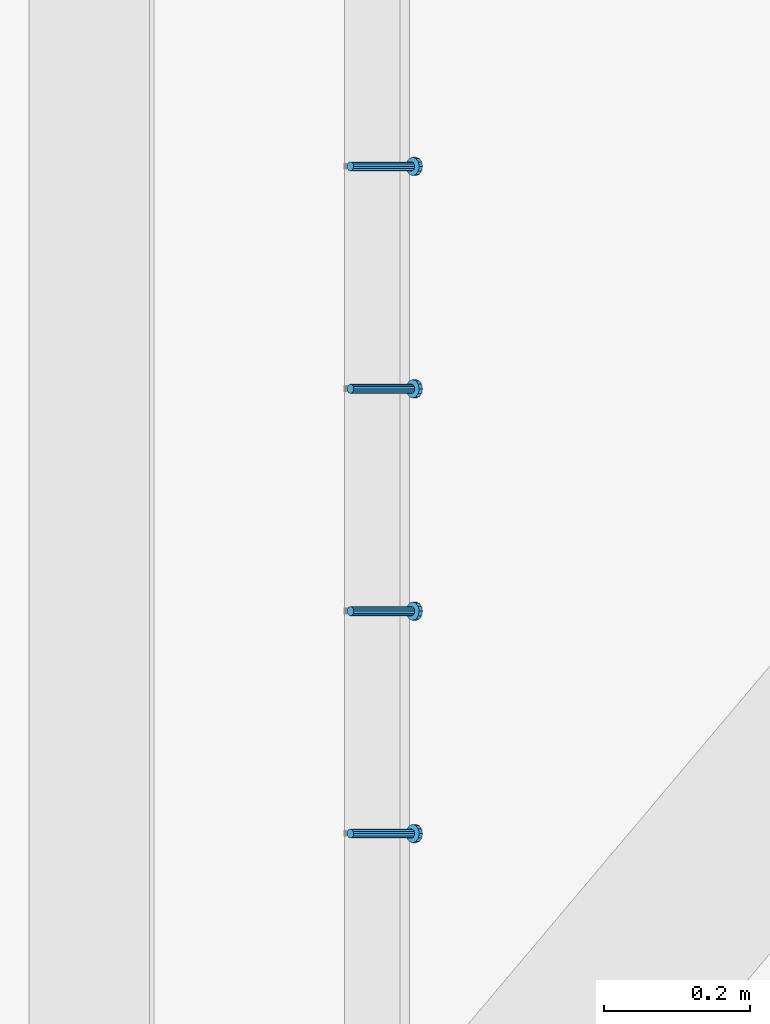
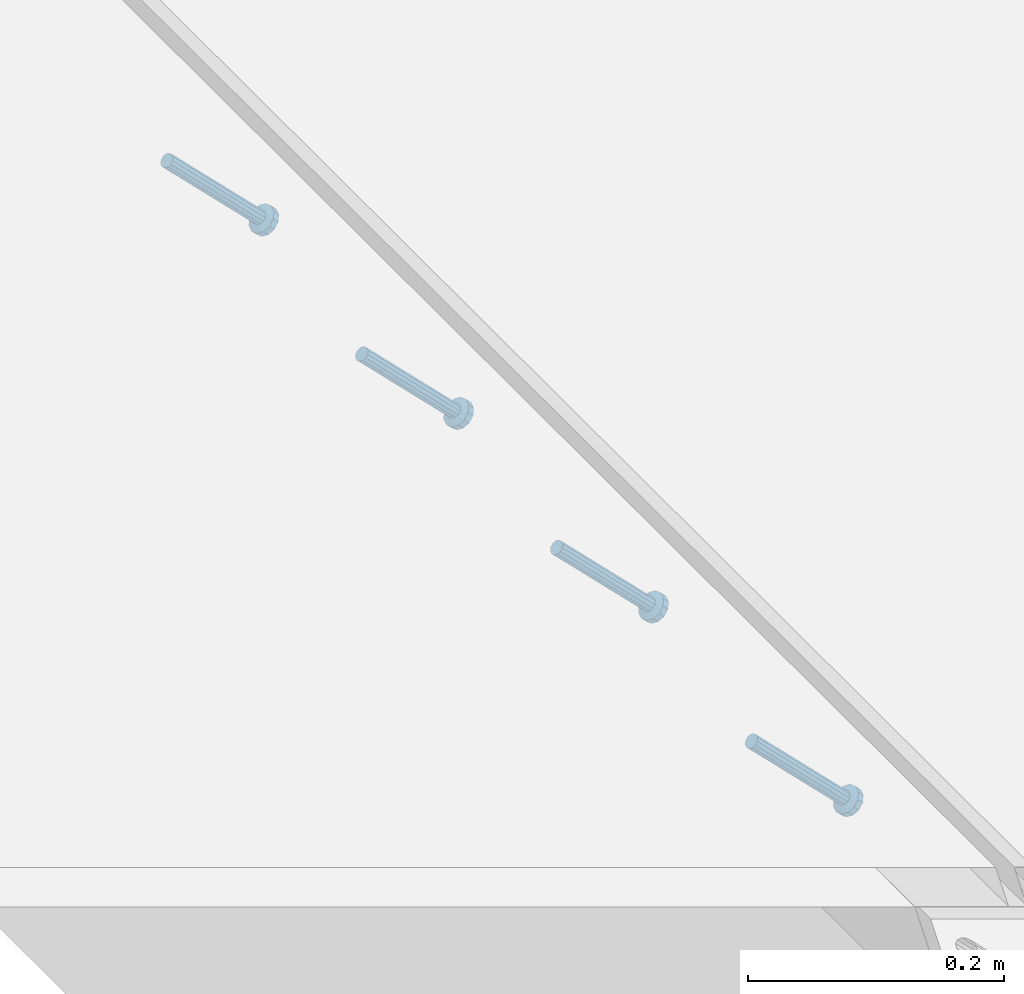
# One storey, part 2127 of 3843: 4 members, 1 element without a shape of its own.
"""IFC2X3 building model written with IfcOpenShell, lengths in millimetres."""

import ifcopenshell
import ifcopenshell.guid

model = None  # the IFC model being written
_history = None  # IfcOwnerHistory: only IFC2X3 demands one
_inside = {}  # id of a spatial element -> (the spatial element, [elements in it])
_under = {}  # id of a project, library or spatial element -> (it, [spatial elements below it])
_declared = {}  # id of a project -> (the project, [libraries it declares])
_typed = {}  # id of a type object -> (the type object, [elements of that type])
_made_of = {}  # id of a material, layer set ... -> (it, [elements and type objects made of it])


def new_model(schema):
    """Start an empty IFC model of exactly this schema.

    Asked for "IFC4X3", IfcOpenShell would pick the latest addendum, in which some entities
    have other attributes; the version numbers below select the first issue.
    IFC2X3 requires an IfcOwnerHistory on every rooted entity: one is made here for all.
    """
    global model, _history
    if schema == "IFC4X3":
        model = ifcopenshell.file(schema_version=(4, 3, 0, 0))
    else:
        model = ifcopenshell.file(schema=schema)
    _inside.clear()
    _under.clear()
    _declared.clear()
    _typed.clear()
    _made_of.clear()
    _history = None
    if model.schema == "IFC2X3":
        org = make("IfcOrganization", Name="unknown")
        user = make(
            "IfcPersonAndOrganization",
            ThePerson=make("IfcPerson", FamilyName="unknown"),
            TheOrganization=org,
        )
        app = make(
            "IfcApplication",
            ApplicationDeveloper=org,
            Version="unknown",
            ApplicationFullName="unknown",
            ApplicationIdentifier="unknown",
        )
        _history = make(
            "IfcOwnerHistory",
            OwningUser=user,
            OwningApplication=app,
            ChangeAction="ADDED",
            CreationDate=0,
        )
    return model


def make(cls, **values):
    """One entity of the class cls with the attributes given. An attribute that is None is left unset."""
    return model.create_entity(
        cls, **{name: value for name, value in values.items() if value is not None}
    )


def rooted(cls, **values):
    """An entity with a GlobalId (a new one), such as an element, a storey or a relation."""
    return make(cls, GlobalId=ifcopenshell.guid.new(), OwnerHistory=_history, **values)


def si_unit(unit_type, name, prefix=None):
    """IfcSIUnit, for example si_unit("LENGTHUNIT", "METRE", prefix="MILLI")."""
    return make("IfcSIUnit", UnitType=unit_type, Prefix=prefix, Name=name)


def assignment(units):
    """IfcUnitAssignment: the units of a project."""
    return None if units is None else make("IfcUnitAssignment", Units=units)


def point(xyz):
    """IfcCartesianPoint."""
    return None if xyz is None else make("IfcCartesianPoint", Coordinates=xyz)


def direction(xyz):
    """IfcDirection."""
    return None if xyz is None else make("IfcDirection", DirectionRatios=xyz)


def frame(location, z_axis=None, x_axis=None):
    """IfcAxis2Placement3D, a coordinate frame: its origin and axes. An axis left out is left unset."""
    return make(
        "IfcAxis2Placement3D",
        Location=point(location),
        Axis=direction(z_axis),
        RefDirection=direction(x_axis),
    )


def origin_with_axes():
    """The frame at (0, 0, 0) with the z axis (0, 0, 1) and the x axis (1, 0, 0) written out."""
    return frame((0.0, 0.0, 0.0), z_axis=(0.0, 0.0, 1.0), x_axis=(1.0, 0.0, 0.0))


def place(relative_to, where):
    """IfcLocalPlacement: puts the frame where relative to a parent placement (None: the world)."""
    return make(
        "IfcLocalPlacement", PlacementRelTo=relative_to, RelativePlacement=where
    )


def context(
    kind, dimensions, precision=None, world=None, true_north=None, identifier=None
):
    """IfcGeometricRepresentationContext, for example the 3D "Model" context."""
    return make(
        "IfcGeometricRepresentationContext",
        ContextIdentifier=identifier,
        ContextType=kind,
        CoordinateSpaceDimension=dimensions,
        Precision=precision,
        WorldCoordinateSystem=world,
        TrueNorth=true_north,
    )


def subcontext(parent, identifier, kind, view, scale=None):
    """IfcGeometricRepresentationSubContext, for example "Body" below "Model"."""
    return make(
        "IfcGeometricRepresentationSubContext",
        ContextIdentifier=identifier,
        ContextType=kind,
        ParentContext=parent,
        TargetScale=scale,
        TargetView=view,
    )


def project(units=None, contexts=None):
    """IfcProject with its units and contexts."""
    return rooted(
        "IfcProject",
        Name="project",
        RepresentationContexts=contexts,
        UnitsInContext=assignment(units),
    )


def spatial(cls, under=None, at=None, **own):
    """A site, building, storey or space (cls), placed at a placement, below another one or the project."""
    s = rooted(cls, ObjectPlacement=at, **own)
    if under is not None:
        _under.setdefault(under.id(), (under, []))[1].append(s)
    return s


def faces_of(points, faces, orient=None, outer=None):
    """IfcFace entities. A face is a list of loops; a loop is a list of indices into points, from 0.

    orient and outer hold one flag for each loop. By default every Orientation is true, the
    first loop of a face is its IfcFaceOuterBound and the others are IfcFaceBound.
    """
    made = []
    for i, loops in enumerate(faces):
        bounds = []
        for j, loop in enumerate(loops):
            is_outer = j == 0 if outer is None else outer[i][j]
            bounds.append(
                make(
                    "IfcFaceOuterBound" if is_outer else "IfcFaceBound",
                    Bound=make("IfcPolyLoop", Polygon=[points[k] for k in loop]),
                    Orientation=True if orient is None else orient[i][j],
                )
            )
        made.append(make("IfcFace", Bounds=bounds))
    return made


def faceted_brep(points, faces, orient=None, outer=None, voids=None):
    """IfcFacetedBrep: a solid bounded by flat faces; with voids (closed shells), ...WithVoids."""
    shared = [point(p) for p in points]
    hull = make("IfcClosedShell", CfsFaces=faces_of(shared, faces, orient, outer))
    if voids is None:
        return make("IfcFacetedBrep", Outer=hull)
    return make(
        "IfcFacetedBrepWithVoids",
        Outer=hull,
        Voids=[
            make(cls, CfsFaces=faces_of(shared, fs, o, b)) for cls, fs, o, b in voids
        ],
    )


def shape(context_of_items, identifier, shape_type, items):
    """IfcShapeRepresentation: the items that make up one representation, for example the "Body"."""
    return make(
        "IfcShapeRepresentation",
        ContextOfItems=context_of_items,
        RepresentationIdentifier=identifier,
        RepresentationType=shape_type,
        Items=items,
    )


def material(Name=None, Category=None):
    """IfcMaterial."""
    return make("IfcMaterial", Name=Name, Category=Category)


def made_of(thing, what):
    """Note that an element or type object is made of a material, layer set ...; save() writes the relation."""
    if what is not None:
        _made_of.setdefault(what.id(), (what, []))[1].append(thing)
    return thing


def type_object(cls, material=None, **own):
    """A type object (cls), such as IfcWallType, which elements share."""
    return made_of(rooted(cls, **own), material)


def element(
    cls,
    number,
    at=None,
    inside=None,
    cuts=None,
    type_object=None,
    material=None,
    context=None,
    identifier="Body",
    shape_type=None,
    held_by="IfcProductDefinitionShape",
    body=None,
    shapes=None,
    **own,
):
    """One element of the class cls, such as IfcWall. Its Tag is "e" and its number.

    at: its placement. inside: the storey or other place that contains it. cuts: it is an
    opening in that element (IfcRelVoidsElement). A single representation is given by context,
    identifier, shape_type and body (its items); several are given by shapes. held_by: the class
    of the entity that holds the representations. save() writes the other relations.
    """
    e = rooted(cls, Tag="e%d" % number, ObjectPlacement=at, **own)
    if body is not None:
        shapes = [shape(context, identifier, shape_type, body)]
    if shapes is not None:
        e.Representation = make(held_by, Representations=shapes)
    if inside is not None:
        _inside.setdefault(inside.id(), (inside, []))[1].append(e)
    if cuts is not None:
        rooted(
            "IfcRelVoidsElement", RelatingBuildingElement=cuts, RelatedOpeningElement=e
        )
    if type_object is not None:
        _typed.setdefault(type_object.id(), (type_object, []))[1].append(e)
    return made_of(e, material)


def aggregate(whole, parts):
    """IfcRelAggregates: a whole, such as a stair, and the parts it consists of."""
    return rooted("IfcRelAggregates", RelatingObject=whole, RelatedObjects=parts)


def save(model, path):
    """Write the relations noted so far, then the file.

    IfcRelAggregates (storeys below a building ...), IfcRelContainedInSpatialStructure (elements
    in a storey), IfcRelDefinesByType, IfcRelAssociatesMaterial and IfcRelDeclares: one each for
    every whole, place, type object, material and project.
    """
    for whole, parts in _under.values():
        aggregate(whole, parts)
    for where, things in _inside.values():
        rooted(
            "IfcRelContainedInSpatialStructure",
            RelatedElements=things,
            RelatingStructure=where,
        )
    for kind, things in _typed.values():
        rooted("IfcRelDefinesByType", RelatedObjects=things, RelatingType=kind)
    for what, things in _made_of.values():
        rooted("IfcRelAssociatesMaterial", RelatedObjects=things, RelatingMaterial=what)
    for by, libraries in _declared.values():
        rooted("IfcRelDeclares", RelatingContext=by, RelatedDefinitions=libraries)
    model.write(path)


model = new_model("IFC2X3")

# Units and contexts
model_context = context("Model", 3, precision=1e-05, world=origin_with_axes())
body_context = subcontext(model_context, "Body", "Model", "MODEL_VIEW")
ifc_project = project(units=[si_unit("LENGTHUNIT", "METRE", prefix="MILLI"), si_unit("AREAUNIT", "SQUARE_METRE"), si_unit("VOLUMEUNIT", "CUBIC_METRE"), si_unit("MASSUNIT", "GRAM", prefix="KILO"), si_unit("TIMEUNIT", "SECOND"), si_unit("PLANEANGLEUNIT", "RADIAN"), si_unit("SOLIDANGLEUNIT", "STERADIAN"), si_unit("THERMODYNAMICTEMPERATUREUNIT", "DEGREE_CELSIUS"), si_unit("LUMINOUSINTENSITYUNIT", "LUMEN")], contexts=[model_context])

# Site, building, storey
site_placement = place(None, origin_with_axes())
site = spatial("IfcSite", under=ifc_project, at=site_placement, CompositionType="ELEMENT")
building_placement = place(site_placement, origin_with_axes())
building = spatial("IfcBuilding", under=site, at=building_placement, Name="Undefined", CompositionType="ELEMENT")
storey_placement = place(building_placement, origin_with_axes())
storey = spatial("IfcBuildingStorey", under=building, at=storey_placement, Name="Undefined", CompositionType="ELEMENT", Elevation=0.0)

# Assembly, members
assembly_placement = place(storey_placement, origin_with_axes())
assembly = element("IfcElementAssembly", 1, at=assembly_placement, inside=storey, Name="EMBED_ANGLE", AssemblyPlace="NOTDEFINED", PredefinedType="RIGID_FRAME")
ifc_material = material(Name="STEEL/A108")
member_type = type_object("IfcMemberType", PredefinedType="NOTDEFINED")
member_1_placement = place(assembly_placement, frame((52815.2360419921, 30797.626609375, 30446.6625), z_axis=(0.0, 1.0, 0.0), x_axis=(0.707106781186548, 0.0, -0.707106781186548)))
member_1 = element("IfcMember", 2, at=member_1_placement, type_object=member_type, material=ifc_material, Name="HEADED STUD ANCHOR", context=body_context, shape_type="Brep", body=[
    faceted_brep([(7.27595761418343e-12, -3.18000006675175, 5.5), (0.0, -5.49999999998363, 3.1800000667572), (118.110000000976, -5.49999999999091, 3.1800000667572), (118.110000000983, -3.18000006675175, 5.5), (0.0, -6.3499999046162, 0.0), (118.110000000968, -6.34999990461256, 0.0), (0.0, -5.49999999998363, -3.1800000667572), (118.110000000976, -5.49999999999091, -3.1800000667572), (7.27595761418343e-12, -3.18000006675175, -5.5), (118.110000000983, -3.18000006675175, -5.5), (7.27595761418343e-12, -1.81898940354586e-12, -6.34999990463257), (118.110000000968, -1.81898940354586e-12, -6.34999990463257), (0.0, 3.18000006675175, -5.5), (118.110000000968, 3.18000006674811, -5.5), (7.27595761418343e-12, 5.49999999998363, -3.1800000667572), (118.110000000983, 5.49999999998363, -3.1800000667572), (7.27595761418343e-12, 6.3499999046162, 0.0), (118.110000000976, 6.34999990461256, 0.0), (7.27595761418343e-12, 5.49999999998363, 3.1800000667572), (118.110000000983, 5.49999999998363, 3.1800000667572), (0.0, 3.18000006675175, 5.5), (118.110000000968, 3.18000006674811, 5.5), (7.27595761418343e-12, -1.81898940354586e-12, 6.34999990463257), (118.110000000968, -1.81898940354586e-12, 6.34999990463257), (120.650000000991, -10.9899997710909, 6.34999990463257), (120.650000000998, -6.34000015257152, 10.9899997711182), (120.650000000991, -12.6999998092379, 0.0), (120.650000000991, -10.9899997710909, -6.34999990463257), (120.650000000998, -6.34000015257152, -10.9899997711182), (120.650000000991, -1.81898940354586e-12, -12.6899995803833), (120.650000000991, 6.34000015257152, -10.9899997711182), (120.650000000998, 10.9899997710909, -6.34999990463257), (120.650000000991, 12.6999998092342, 0.0), (120.650000000998, 10.9899997710909, 6.34999990463257), (120.650000000991, 6.34000015257152, 10.9899997711182), (120.650000000991, -1.81898940354586e-12, 12.6899995803833), (127.000000001048, -10.9899997710945, 6.34999990463257), (127.000000001048, -6.34000015257152, 10.9899997711182), (127.000000001048, -12.6999998092342, 0.0), (127.000000001048, -10.9899997710945, -6.34999990463257), (127.000000001048, -6.34000015257152, -10.9899997711182), (127.000000001048, 1.81898940354586e-12, -12.6899995803833), (127.000000001048, 6.34000015256788, -10.9899997711182), (127.000000001048, 10.9899997710909, -6.34999990463257), (127.000000001048, 12.6999998092379, 0.0), (127.000000001048, 10.9899997710909, 6.34999990463257), (127.000000001048, 6.34000015256788, 10.9899997711182), (127.000000001048, 1.81898940354586e-12, 12.6899995803833)], [[[0, 1, 2, 3]], [[1, 4, 5, 2]], [[4, 6, 7, 5]], [[6, 8, 9, 7]], [[8, 10, 11, 9]], [[10, 12, 13, 11]], [[12, 14, 15, 13]], [[14, 16, 17, 15]], [[16, 18, 19, 17]], [[18, 20, 21, 19]], [[20, 22, 23, 21]], [[22, 0, 3, 23]], [[22, 20, 18, 16, 14, 12, 10, 8, 6, 4, 1, 0]], [[3, 2, 24, 25]], [[2, 5, 26, 24]], [[5, 7, 27, 26]], [[7, 9, 28, 27]], [[9, 11, 29, 28]], [[11, 13, 30, 29]], [[13, 15, 31, 30]], [[15, 17, 32, 31]], [[17, 19, 33, 32]], [[19, 21, 34, 33]], [[21, 23, 35, 34]], [[23, 3, 25, 35]], [[25, 24, 36, 37]], [[24, 26, 38, 36]], [[26, 27, 39, 38]], [[27, 28, 40, 39]], [[28, 29, 41, 40]], [[29, 30, 42, 41]], [[30, 31, 43, 42]], [[31, 32, 44, 43]], [[32, 33, 45, 44]], [[33, 34, 46, 45]], [[34, 35, 47, 46]], [[35, 25, 37, 47]], [[38, 39, 40, 41, 42, 43, 44, 45, 46, 47, 37, 36]]]),
])
member_2_placement = place(assembly_placement, frame((52815.2360419921, 31102.426609375, 30446.6625), z_axis=(0.0, 1.0, 0.0), x_axis=(0.707106781186548, 0.0, -0.707106781186548)))
member_2 = element("IfcMember", 3, at=member_2_placement, type_object=member_type, material=ifc_material, Name="HEADED STUD ANCHOR", context=body_context, shape_type="Brep", body=[
    faceted_brep([(7.27595761418343e-12, -3.18000006675175, 5.5), (0.0, -5.49999999998363, 3.1800000667572), (118.110000000976, -5.49999999999091, 3.1800000667572), (118.110000000983, -3.18000006675175, 5.5), (0.0, -6.3499999046162, 0.0), (118.110000000968, -6.34999990461256, 0.0), (0.0, -5.49999999998363, -3.1800000667572), (118.110000000976, -5.49999999999091, -3.1800000667572), (7.27595761418343e-12, -3.18000006675175, -5.5), (118.110000000983, -3.18000006675175, -5.5), (7.27595761418343e-12, -1.81898940354586e-12, -6.34999990463257), (118.110000000968, -1.81898940354586e-12, -6.34999990463257), (0.0, 3.18000006675175, -5.5), (118.110000000968, 3.18000006674811, -5.5), (7.27595761418343e-12, 5.49999999998363, -3.1800000667572), (118.110000000983, 5.49999999998363, -3.1800000667572), (7.27595761418343e-12, 6.3499999046162, 0.0), (118.110000000976, 6.34999990461256, 0.0), (7.27595761418343e-12, 5.49999999998363, 3.1800000667572), (118.110000000983, 5.49999999998363, 3.1800000667572), (0.0, 3.18000006675175, 5.5), (118.110000000968, 3.18000006674811, 5.5), (7.27595761418343e-12, -1.81898940354586e-12, 6.34999990463257), (118.110000000968, -1.81898940354586e-12, 6.34999990463257), (120.650000000991, -10.9899997710909, 6.34999990463257), (120.650000000998, -6.34000015257152, 10.9899997711182), (120.650000000991, -12.6999998092379, 0.0), (120.650000000991, -10.9899997710909, -6.34999990463257), (120.650000000998, -6.34000015257152, -10.9899997711182), (120.650000000991, -1.81898940354586e-12, -12.6899995803833), (120.650000000991, 6.34000015257152, -10.9899997711182), (120.650000000998, 10.9899997710909, -6.34999990463257), (120.650000000991, 12.6999998092342, 0.0), (120.650000000998, 10.9899997710909, 6.34999990463257), (120.650000000991, 6.34000015257152, 10.9899997711182), (120.650000000991, -1.81898940354586e-12, 12.6899995803833), (127.000000001048, -10.9899997710945, 6.34999990463257), (127.000000001048, -6.34000015257152, 10.9899997711182), (127.000000001048, -12.6999998092342, 0.0), (127.000000001048, -10.9899997710945, -6.34999990463257), (127.000000001048, -6.34000015257152, -10.9899997711182), (127.000000001048, 1.81898940354586e-12, -12.6899995803833), (127.000000001048, 6.34000015256788, -10.9899997711182), (127.000000001048, 10.9899997710909, -6.34999990463257), (127.000000001048, 12.6999998092379, 0.0), (127.000000001048, 10.9899997710909, 6.34999990463257), (127.000000001048, 6.34000015256788, 10.9899997711182), (127.000000001048, 1.81898940354586e-12, 12.6899995803833)], [[[0, 1, 2, 3]], [[1, 4, 5, 2]], [[4, 6, 7, 5]], [[6, 8, 9, 7]], [[8, 10, 11, 9]], [[10, 12, 13, 11]], [[12, 14, 15, 13]], [[14, 16, 17, 15]], [[16, 18, 19, 17]], [[18, 20, 21, 19]], [[20, 22, 23, 21]], [[22, 0, 3, 23]], [[22, 20, 18, 16, 14, 12, 10, 8, 6, 4, 1, 0]], [[3, 2, 24, 25]], [[2, 5, 26, 24]], [[5, 7, 27, 26]], [[7, 9, 28, 27]], [[9, 11, 29, 28]], [[11, 13, 30, 29]], [[13, 15, 31, 30]], [[15, 17, 32, 31]], [[17, 19, 33, 32]], [[19, 21, 34, 33]], [[21, 23, 35, 34]], [[23, 3, 25, 35]], [[25, 24, 36, 37]], [[24, 26, 38, 36]], [[26, 27, 39, 38]], [[27, 28, 40, 39]], [[28, 29, 41, 40]], [[29, 30, 42, 41]], [[30, 31, 43, 42]], [[31, 32, 44, 43]], [[32, 33, 45, 44]], [[33, 34, 46, 45]], [[34, 35, 47, 46]], [[35, 25, 37, 47]], [[38, 39, 40, 41, 42, 43, 44, 45, 46, 47, 37, 36]]]),
])
member_3_placement = place(assembly_placement, frame((52815.2360419921, 31407.226609375, 30446.6625), z_axis=(0.0, 1.0, 0.0), x_axis=(0.707106781186548, 0.0, -0.707106781186548)))
member_3 = element("IfcMember", 4, at=member_3_placement, type_object=member_type, material=ifc_material, Name="HEADED STUD ANCHOR", context=body_context, shape_type="Brep", body=[
    faceted_brep([(7.27595761418343e-12, -3.18000006675175, 5.5), (0.0, -5.49999999998363, 3.1800000667572), (118.110000000976, -5.49999999999091, 3.1800000667572), (118.110000000983, -3.18000006675175, 5.5), (0.0, -6.3499999046162, 0.0), (118.110000000968, -6.34999990461256, 0.0), (0.0, -5.49999999998363, -3.1800000667572), (118.110000000976, -5.49999999999091, -3.1800000667572), (7.27595761418343e-12, -3.18000006675175, -5.5), (118.110000000983, -3.18000006675175, -5.5), (7.27595761418343e-12, -1.81898940354586e-12, -6.34999990463257), (118.110000000968, -1.81898940354586e-12, -6.34999990463257), (0.0, 3.18000006675175, -5.5), (118.110000000968, 3.18000006674811, -5.5), (7.27595761418343e-12, 5.49999999998363, -3.1800000667572), (118.110000000983, 5.49999999998363, -3.1800000667572), (7.27595761418343e-12, 6.3499999046162, 0.0), (118.110000000976, 6.34999990461256, 0.0), (7.27595761418343e-12, 5.49999999998363, 3.1800000667572), (118.110000000983, 5.49999999998363, 3.1800000667572), (0.0, 3.18000006675175, 5.5), (118.110000000968, 3.18000006674811, 5.5), (7.27595761418343e-12, -1.81898940354586e-12, 6.34999990463257), (118.110000000968, -1.81898940354586e-12, 6.34999990463257), (120.650000000991, -10.9899997710909, 6.34999990463257), (120.650000000998, -6.34000015257152, 10.9899997711182), (120.650000000991, -12.6999998092379, 0.0), (120.650000000991, -10.9899997710909, -6.34999990463257), (120.650000000998, -6.34000015257152, -10.9899997711182), (120.650000000991, -1.81898940354586e-12, -12.6899995803833), (120.650000000991, 6.34000015257152, -10.9899997711182), (120.650000000998, 10.9899997710909, -6.34999990463257), (120.650000000991, 12.6999998092342, 0.0), (120.650000000998, 10.9899997710909, 6.34999990463257), (120.650000000991, 6.34000015257152, 10.9899997711182), (120.650000000991, -1.81898940354586e-12, 12.6899995803833), (127.000000001048, -10.9899997710945, 6.34999990463257), (127.000000001048, -6.34000015257152, 10.9899997711182), (127.000000001048, -12.6999998092342, 0.0), (127.000000001048, -10.9899997710945, -6.34999990463257), (127.000000001048, -6.34000015257152, -10.9899997711182), (127.000000001048, 1.81898940354586e-12, -12.6899995803833), (127.000000001048, 6.34000015256788, -10.9899997711182), (127.000000001048, 10.9899997710909, -6.34999990463257), (127.000000001048, 12.6999998092379, 0.0), (127.000000001048, 10.9899997710909, 6.34999990463257), (127.000000001048, 6.34000015256788, 10.9899997711182), (127.000000001048, 1.81898940354586e-12, 12.6899995803833)], [[[0, 1, 2, 3]], [[1, 4, 5, 2]], [[4, 6, 7, 5]], [[6, 8, 9, 7]], [[8, 10, 11, 9]], [[10, 12, 13, 11]], [[12, 14, 15, 13]], [[14, 16, 17, 15]], [[16, 18, 19, 17]], [[18, 20, 21, 19]], [[20, 22, 23, 21]], [[22, 0, 3, 23]], [[22, 20, 18, 16, 14, 12, 10, 8, 6, 4, 1, 0]], [[3, 2, 24, 25]], [[2, 5, 26, 24]], [[5, 7, 27, 26]], [[7, 9, 28, 27]], [[9, 11, 29, 28]], [[11, 13, 30, 29]], [[13, 15, 31, 30]], [[15, 17, 32, 31]], [[17, 19, 33, 32]], [[19, 21, 34, 33]], [[21, 23, 35, 34]], [[23, 3, 25, 35]], [[25, 24, 36, 37]], [[24, 26, 38, 36]], [[26, 27, 39, 38]], [[27, 28, 40, 39]], [[28, 29, 41, 40]], [[29, 30, 42, 41]], [[30, 31, 43, 42]], [[31, 32, 44, 43]], [[32, 33, 45, 44]], [[33, 34, 46, 45]], [[34, 35, 47, 46]], [[35, 25, 37, 47]], [[38, 39, 40, 41, 42, 43, 44, 45, 46, 47, 37, 36]]]),
])
member_4_placement = place(assembly_placement, frame((52815.2360419921, 31712.026609375, 30446.6625), z_axis=(0.0, 1.0, 0.0), x_axis=(0.707106781186548, 0.0, -0.707106781186548)))
member_4 = element("IfcMember", 5, at=member_4_placement, type_object=member_type, material=ifc_material, Name="HEADED STUD ANCHOR", context=body_context, shape_type="Brep", body=[
    faceted_brep([(7.27595761418343e-12, -3.18000006675175, 5.5), (0.0, -5.49999999998363, 3.1800000667572), (118.110000000976, -5.49999999999091, 3.1800000667572), (118.110000000983, -3.18000006675175, 5.5), (0.0, -6.3499999046162, 0.0), (118.110000000968, -6.34999990461256, 0.0), (0.0, -5.49999999998363, -3.1800000667572), (118.110000000976, -5.49999999999091, -3.1800000667572), (7.27595761418343e-12, -3.18000006675175, -5.5), (118.110000000983, -3.18000006675175, -5.5), (7.27595761418343e-12, -1.81898940354586e-12, -6.34999990463257), (118.110000000968, -1.81898940354586e-12, -6.34999990463257), (0.0, 3.18000006675175, -5.5), (118.110000000968, 3.18000006674811, -5.5), (7.27595761418343e-12, 5.49999999998363, -3.1800000667572), (118.110000000983, 5.49999999998363, -3.1800000667572), (7.27595761418343e-12, 6.3499999046162, 0.0), (118.110000000976, 6.34999990461256, 0.0), (7.27595761418343e-12, 5.49999999998363, 3.1800000667572), (118.110000000983, 5.49999999998363, 3.1800000667572), (0.0, 3.18000006675175, 5.5), (118.110000000968, 3.18000006674811, 5.5), (7.27595761418343e-12, -1.81898940354586e-12, 6.34999990463257), (118.110000000968, -1.81898940354586e-12, 6.34999990463257), (120.650000000991, -10.9899997710909, 6.34999990463257), (120.650000000998, -6.34000015257152, 10.9899997711182), (120.650000000991, -12.6999998092379, 0.0), (120.650000000991, -10.9899997710909, -6.34999990463257), (120.650000000998, -6.34000015257152, -10.9899997711182), (120.650000000991, -1.81898940354586e-12, -12.6899995803833), (120.650000000991, 6.34000015257152, -10.9899997711182), (120.650000000998, 10.9899997710909, -6.34999990463257), (120.650000000991, 12.6999998092342, 0.0), (120.650000000998, 10.9899997710909, 6.34999990463257), (120.650000000991, 6.34000015257152, 10.9899997711182), (120.650000000991, -1.81898940354586e-12, 12.6899995803833), (127.000000001048, -10.9899997710945, 6.34999990463257), (127.000000001048, -6.34000015257152, 10.9899997711182), (127.000000001048, -12.6999998092342, 0.0), (127.000000001048, -10.9899997710945, -6.34999990463257), (127.000000001048, -6.34000015257152, -10.9899997711182), (127.000000001048, 1.81898940354586e-12, -12.6899995803833), (127.000000001048, 6.34000015256788, -10.9899997711182), (127.000000001048, 10.9899997710909, -6.34999990463257), (127.000000001048, 12.6999998092379, 0.0), (127.000000001048, 10.9899997710909, 6.34999990463257), (127.000000001048, 6.34000015256788, 10.9899997711182), (127.000000001048, 1.81898940354586e-12, 12.6899995803833)], [[[0, 1, 2, 3]], [[1, 4, 5, 2]], [[4, 6, 7, 5]], [[6, 8, 9, 7]], [[8, 10, 11, 9]], [[10, 12, 13, 11]], [[12, 14, 15, 13]], [[14, 16, 17, 15]], [[16, 18, 19, 17]], [[18, 20, 21, 19]], [[20, 22, 23, 21]], [[22, 0, 3, 23]], [[22, 20, 18, 16, 14, 12, 10, 8, 6, 4, 1, 0]], [[3, 2, 24, 25]], [[2, 5, 26, 24]], [[5, 7, 27, 26]], [[7, 9, 28, 27]], [[9, 11, 29, 28]], [[11, 13, 30, 29]], [[13, 15, 31, 30]], [[15, 17, 32, 31]], [[17, 19, 33, 32]], [[19, 21, 34, 33]], [[21, 23, 35, 34]], [[23, 3, 25, 35]], [[25, 24, 36, 37]], [[24, 26, 38, 36]], [[26, 27, 39, 38]], [[27, 28, 40, 39]], [[28, 29, 41, 40]], [[29, 30, 42, 41]], [[30, 31, 43, 42]], [[31, 32, 44, 43]], [[32, 33, 45, 44]], [[33, 34, 46, 45]], [[34, 35, 47, 46]], [[35, 25, 37, 47]], [[38, 39, 40, 41, 42, 43, 44, 45, 46, 47, 37, 36]]]),
])
aggregate(assembly, [member_1, member_2, member_3, member_4])

save(model, "model.ifc")
